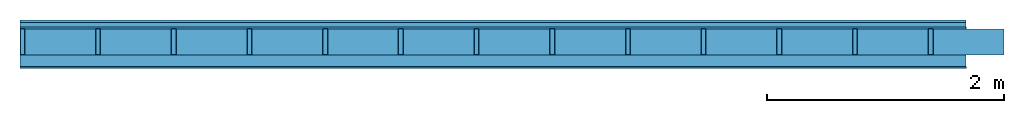
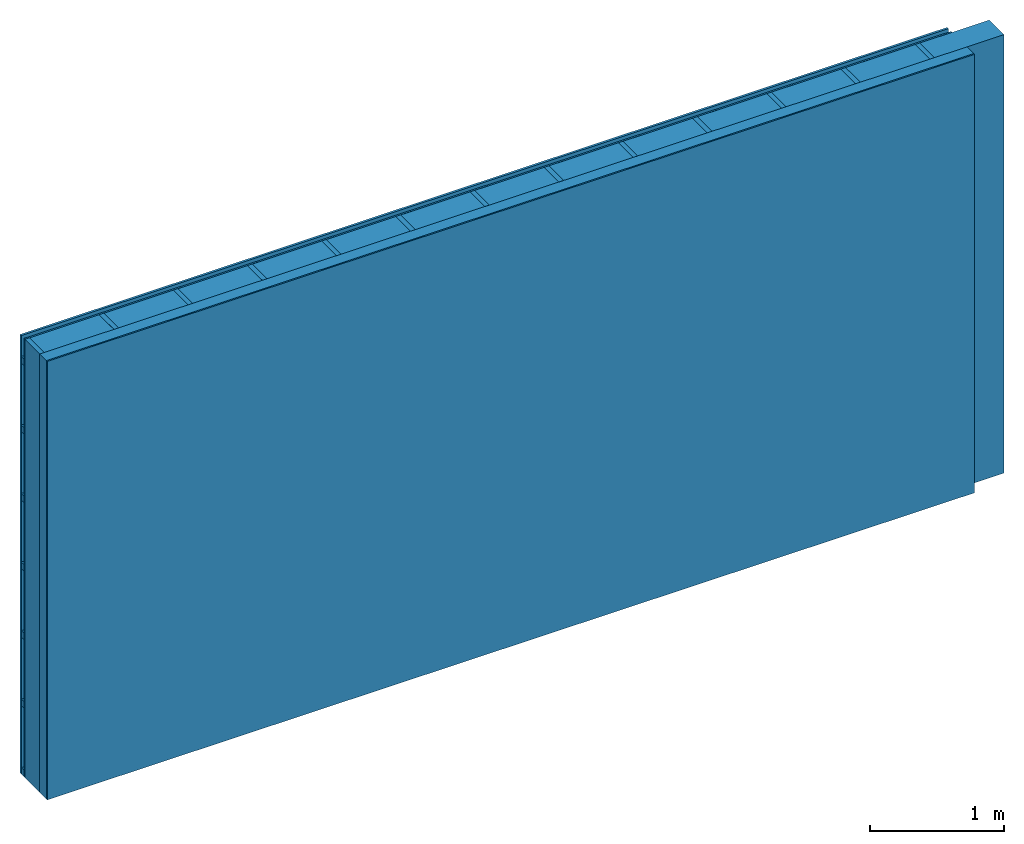
# One storey: 4 plates, 3 members, 1 element without a shape of its own.
"""IFC4 building model written with IfcOpenShell, lengths in metres."""

from ifc_helpers import new_model, si_unit, derived_unit, direction, frame, frame_2d, origin, origin_with_axes, place, context, project, spatial, rectangle, extrude, material, layer, layer_set, type_object, element, aggregate, save


model = new_model("IFC4")

# Units and contexts
plan_context = context("Plan", 3, precision=1e-05, world=origin(), true_north=direction((0.0, 1.0)))
model_context = context("Model", 3, precision=1e-05, world=origin(), true_north=direction((0.0, 1.0)))
ifc_project = project(units=[si_unit("LENGTHUNIT", "METRE"), derived_unit("SOUNDPRESSUREUNIT", [(si_unit("PRESSUREUNIT", "PASCAL", prefix="MICRO"), 0)]), si_unit("ENERGYUNIT", "JOULE", prefix="MEGA"), si_unit("MASSUNIT", "GRAM", prefix="KILO"), derived_unit("THERMALTRANSMITTANCEUNIT", [(si_unit("POWERUNIT", "WATT"), 1), (si_unit("AREAUNIT", "SQUARE_METRE"), -1), (si_unit("THERMODYNAMICTEMPERATUREUNIT", "KELVIN"), -1)]), derived_unit("AREADENSITYUNIT", [(si_unit("MASSUNIT", "GRAM", prefix="KILO"), 1), (si_unit("AREAUNIT", "SQUARE_METRE"), -1)]), derived_unit("USERDEFINED", [(si_unit("ENERGYUNIT", "JOULE", prefix="MEGA"), 1), (si_unit("AREAUNIT", "SQUARE_METRE"), -1)])], contexts=[plan_context, model_context])

# Site, building, storey
site = spatial("IfcSite", under=ifc_project)
building_placement = place(None, origin())
building = spatial("IfcBuilding", under=site, at=building_placement)
storey_placement = place(building_placement, origin())
storey = spatial("IfcBuildingStorey", under=building, at=storey_placement)

# Wall, members, plates
ifc_material_1 = material(Name="Wood cladding horizontal, closed")
ifc_layer_1 = layer(ifc_material_1, 0.02, Name="Cover 1st layer")
ifc_layer_2 = layer(None, 0.04, Name="Battens / profiles (ventilation)")
ifc_material_2 = material(Category="03.007")
ifc_layer_3 = layer(ifc_material_2, 0.015, Name="outside 1st layer")
ifc_material_3 = material(Name="of the art")
ifc_layer_4 = layer(ifc_material_3, 0.0, Name="Bond")
ifc_layer_5 = layer(None, 0.22, Name="Support")
ifc_layer_6 = layer(ifc_material_3, 0.0, Name="Bond")
ifc_material_4 = material(Name="Solid timber panel")
ifc_layer_7 = layer(ifc_material_4, 0.1, Name="1st layer")
ifc_material_5 = material(Name="Plasterboard type A", Category="03.008")
ifc_layer_8 = layer(ifc_material_5, 0.0125, Name="Covering 1st layer")
ifc_material_6 = material(Name="joints", Category="04.017")
ifc_layer_9 = layer(ifc_material_6, 0.0, Name="Surface")
ifc_layer_set = layer_set([ifc_layer_1, ifc_layer_2, ifc_layer_3, ifc_layer_4, ifc_layer_5, ifc_layer_6, ifc_layer_7, ifc_layer_8, ifc_layer_9])
wall_type = type_object("IfcWallType", Name="D0991", PredefinedType="NOTDEFINED", material=ifc_layer_set)
wall_placement = place(None, frame((0.0, 0.0, 0.0), z_axis=(0.0, -1.0, 0.0), x_axis=(1.0, 0.0, 0.0)))
wall = element("IfcWall", 1, at=wall_placement, inside=storey, type_object=wall_type, material=ifc_layer_set, Name="Wall #1")
ifc_material_7 = material()
member_1_placement = place(wall_placement, origin())
member_1 = element("IfcMember", 2, at=member_1_placement, material=ifc_material_7, Name="Battens / profiles (ventilation)", context=plan_context, shape_type="SweptSolid", body=[
    extrude(rectangle(XDim=0.06, YDim=0.04, at=frame_2d((0.03, 0.02), x_axis=(1.0, 0.0))), frame((0.0, 0.0, 0.02), z_axis=(1.0, 0.0, 0.0), x_axis=(0.0, 1.0, 0.0)), (0.0, 0.0, 1.0), 8.0),
    extrude(rectangle(XDim=0.06, YDim=0.04, at=frame_2d((0.03, 0.02), x_axis=(1.0, 0.0))), frame((0.0, 0.625, 0.02), z_axis=(1.0, 0.0, 0.0), x_axis=(0.0, 1.0, 0.0)), (0.0, 0.0, 1.0), 8.0),
    extrude(rectangle(XDim=0.06, YDim=0.04, at=frame_2d((0.03, 0.02), x_axis=(1.0, 0.0))), frame((0.0, 1.25, 0.02), z_axis=(1.0, 0.0, 0.0), x_axis=(0.0, 1.0, 0.0)), (0.0, 0.0, 1.0), 8.0),
    extrude(rectangle(XDim=0.06, YDim=0.04, at=frame_2d((0.03, 0.02), x_axis=(1.0, 0.0))), frame((0.0, 1.875, 0.02), z_axis=(1.0, 0.0, 0.0), x_axis=(0.0, 1.0, 0.0)), (0.0, 0.0, 1.0), 8.0),
    extrude(rectangle(XDim=0.06, YDim=0.04, at=frame_2d((0.03, 0.02), x_axis=(1.0, 0.0))), frame((0.0, 2.5, 0.02), z_axis=(1.0, 0.0, 0.0), x_axis=(0.0, 1.0, 0.0)), (0.0, 0.0, 1.0), 8.0),
    extrude(rectangle(XDim=0.06, YDim=0.04, at=frame_2d((0.03, 0.02), x_axis=(1.0, 0.0))), frame((0.0, 3.125, 0.02), z_axis=(1.0, 0.0, 0.0), x_axis=(0.0, 1.0, 0.0)), (0.0, 0.0, 1.0), 8.0),
    extrude(rectangle(XDim=0.06, YDim=0.04, at=frame_2d((0.03, 0.02), x_axis=(1.0, 0.0))), frame((0.0, 3.75, 0.02), z_axis=(1.0, 0.0, 0.0), x_axis=(0.0, 1.0, 0.0)), (0.0, 0.0, 1.0), 8.0),
])
ifc_material_8 = material()
member_2_placement = place(wall_placement, origin())
member_2 = element("IfcMember", 3, at=member_2_placement, material=ifc_material_8, Name="Support", context=plan_context, shape_type="SweptSolid", body=[
    extrude(rectangle(XDim=0.04, YDim=0.22, at=frame_2d((0.02, 0.11), x_axis=(1.0, 0.0))), frame((0.0, 4.0, 0.075), z_axis=(0.0, -1.0, 0.0), x_axis=(1.0, 0.0, 0.0)), (0.0, 0.0, 1.0), 4.0),
    extrude(rectangle(XDim=0.04, YDim=0.22, at=frame_2d((0.02, 0.11), x_axis=(1.0, 0.0))), frame((0.64, 4.0, 0.075), z_axis=(0.0, -1.0, 0.0), x_axis=(1.0, 0.0, 0.0)), (0.0, 0.0, 1.0), 4.0),
    extrude(rectangle(XDim=0.04, YDim=0.22, at=frame_2d((0.02, 0.11), x_axis=(1.0, 0.0))), frame((1.28, 4.0, 0.075), z_axis=(0.0, -1.0, 0.0), x_axis=(1.0, 0.0, 0.0)), (0.0, 0.0, 1.0), 4.0),
    extrude(rectangle(XDim=0.04, YDim=0.22, at=frame_2d((0.02, 0.11), x_axis=(1.0, 0.0))), frame((1.92, 4.0, 0.075), z_axis=(0.0, -1.0, 0.0), x_axis=(1.0, 0.0, 0.0)), (0.0, 0.0, 1.0), 4.0),
    extrude(rectangle(XDim=0.04, YDim=0.22, at=frame_2d((0.02, 0.11), x_axis=(1.0, 0.0))), frame((2.56, 4.0, 0.075), z_axis=(0.0, -1.0, 0.0), x_axis=(1.0, 0.0, 0.0)), (0.0, 0.0, 1.0), 4.0),
    extrude(rectangle(XDim=0.04, YDim=0.22, at=frame_2d((0.02, 0.11), x_axis=(1.0, 0.0))), frame((3.2, 4.0, 0.075), z_axis=(0.0, -1.0, 0.0), x_axis=(1.0, 0.0, 0.0)), (0.0, 0.0, 1.0), 4.0),
    extrude(rectangle(XDim=0.04, YDim=0.22, at=frame_2d((0.02, 0.11), x_axis=(1.0, 0.0))), frame((3.84, 4.0, 0.075), z_axis=(0.0, -1.0, 0.0), x_axis=(1.0, 0.0, 0.0)), (0.0, 0.0, 1.0), 4.0),
    extrude(rectangle(XDim=0.04, YDim=0.22, at=frame_2d((0.02, 0.11), x_axis=(1.0, 0.0))), frame((4.48, 4.0, 0.075), z_axis=(0.0, -1.0, 0.0), x_axis=(1.0, 0.0, 0.0)), (0.0, 0.0, 1.0), 4.0),
    extrude(rectangle(XDim=0.04, YDim=0.22, at=frame_2d((0.02, 0.11), x_axis=(1.0, 0.0))), frame((5.12, 4.0, 0.075), z_axis=(0.0, -1.0, 0.0), x_axis=(1.0, 0.0, 0.0)), (0.0, 0.0, 1.0), 4.0),
    extrude(rectangle(XDim=0.04, YDim=0.22, at=frame_2d((0.02, 0.11), x_axis=(1.0, 0.0))), frame((5.76, 4.0, 0.075), z_axis=(0.0, -1.0, 0.0), x_axis=(1.0, 0.0, 0.0)), (0.0, 0.0, 1.0), 4.0),
    extrude(rectangle(XDim=0.04, YDim=0.22, at=frame_2d((0.02, 0.11), x_axis=(1.0, 0.0))), frame((6.4, 4.0, 0.075), z_axis=(0.0, -1.0, 0.0), x_axis=(1.0, 0.0, 0.0)), (0.0, 0.0, 1.0), 4.0),
    extrude(rectangle(XDim=0.04, YDim=0.22, at=frame_2d((0.02, 0.11), x_axis=(1.0, 0.0))), frame((7.04, 4.0, 0.075), z_axis=(0.0, -1.0, 0.0), x_axis=(1.0, 0.0, 0.0)), (0.0, 0.0, 1.0), 4.0),
    extrude(rectangle(XDim=0.04, YDim=0.22, at=frame_2d((0.02, 0.11), x_axis=(1.0, 0.0))), frame((7.68, 4.0, 0.075), z_axis=(0.0, -1.0, 0.0), x_axis=(1.0, 0.0, 0.0)), (0.0, 0.0, 1.0), 4.0),
])
ifc_material_9 = material(Name="Mineral wool")
member_3_placement = place(wall_placement, origin())
member_3 = element("IfcMember", 4, at=member_3_placement, material=ifc_material_9, Name="Cavity", context=plan_context, shape_type="SweptSolid", body=[
    extrude(rectangle(XDim=0.6, YDim=0.22, at=frame_2d((0.3, 0.11), x_axis=(1.0, 0.0))), frame((0.04, 4.0, 0.075), z_axis=(0.0, -1.0, 0.0), x_axis=(1.0, 0.0, 0.0)), (0.0, 0.0, 1.0), 4.0),
    extrude(rectangle(XDim=0.6, YDim=0.22, at=frame_2d((0.3, 0.11), x_axis=(1.0, 0.0))), frame((0.68, 4.0, 0.075), z_axis=(0.0, -1.0, 0.0), x_axis=(1.0, 0.0, 0.0)), (0.0, 0.0, 1.0), 4.0),
    extrude(rectangle(XDim=0.6, YDim=0.22, at=frame_2d((0.3, 0.11), x_axis=(1.0, 0.0))), frame((1.32, 4.0, 0.075), z_axis=(0.0, -1.0, 0.0), x_axis=(1.0, 0.0, 0.0)), (0.0, 0.0, 1.0), 4.0),
    extrude(rectangle(XDim=0.6, YDim=0.22, at=frame_2d((0.3, 0.11), x_axis=(1.0, 0.0))), frame((1.96, 4.0, 0.075), z_axis=(0.0, -1.0, 0.0), x_axis=(1.0, 0.0, 0.0)), (0.0, 0.0, 1.0), 4.0),
    extrude(rectangle(XDim=0.6, YDim=0.22, at=frame_2d((0.3, 0.11), x_axis=(1.0, 0.0))), frame((2.6, 4.0, 0.075), z_axis=(0.0, -1.0, 0.0), x_axis=(1.0, 0.0, 0.0)), (0.0, 0.0, 1.0), 4.0),
    extrude(rectangle(XDim=0.6, YDim=0.22, at=frame_2d((0.3, 0.11), x_axis=(1.0, 0.0))), frame((3.24, 4.0, 0.075), z_axis=(0.0, -1.0, 0.0), x_axis=(1.0, 0.0, 0.0)), (0.0, 0.0, 1.0), 4.0),
    extrude(rectangle(XDim=0.6, YDim=0.22, at=frame_2d((0.3, 0.11), x_axis=(1.0, 0.0))), frame((3.88, 4.0, 0.075), z_axis=(0.0, -1.0, 0.0), x_axis=(1.0, 0.0, 0.0)), (0.0, 0.0, 1.0), 4.0),
    extrude(rectangle(XDim=0.6, YDim=0.22, at=frame_2d((0.3, 0.11), x_axis=(1.0, 0.0))), frame((4.52, 4.0, 0.075), z_axis=(0.0, -1.0, 0.0), x_axis=(1.0, 0.0, 0.0)), (0.0, 0.0, 1.0), 4.0),
    extrude(rectangle(XDim=0.6, YDim=0.22, at=frame_2d((0.3, 0.11), x_axis=(1.0, 0.0))), frame((5.16, 4.0, 0.075), z_axis=(0.0, -1.0, 0.0), x_axis=(1.0, 0.0, 0.0)), (0.0, 0.0, 1.0), 4.0),
    extrude(rectangle(XDim=0.6, YDim=0.22, at=frame_2d((0.3, 0.11), x_axis=(1.0, 0.0))), frame((5.8, 4.0, 0.075), z_axis=(0.0, -1.0, 0.0), x_axis=(1.0, 0.0, 0.0)), (0.0, 0.0, 1.0), 4.0),
    extrude(rectangle(XDim=0.6, YDim=0.22, at=frame_2d((0.3, 0.11), x_axis=(1.0, 0.0))), frame((6.44, 4.0, 0.075), z_axis=(0.0, -1.0, 0.0), x_axis=(1.0, 0.0, 0.0)), (0.0, 0.0, 1.0), 4.0),
    extrude(rectangle(XDim=0.6, YDim=0.22, at=frame_2d((0.3, 0.11), x_axis=(1.0, 0.0))), frame((7.08, 4.0, 0.075), z_axis=(0.0, -1.0, 0.0), x_axis=(1.0, 0.0, 0.0)), (0.0, 0.0, 1.0), 4.0),
    extrude(rectangle(XDim=0.6, YDim=0.22, at=frame_2d((0.3, 0.11), x_axis=(1.0, 0.0))), frame((7.72, 4.0, 0.075), z_axis=(0.0, -1.0, 0.0), x_axis=(1.0, 0.0, 0.0)), (0.0, 0.0, 1.0), 4.0),
])
plate_1_placement = place(wall_placement, origin())
plate_1 = element("IfcPlate", 5, at=plate_1_placement, material=ifc_material_1, Name="Cover 1st layer", context=plan_context, shape_type="SweptSolid", body=[
    extrude(rectangle(XDim=8.0, YDim=4.0, at=frame_2d((4.0, 2.0), x_axis=(1.0, 0.0))), origin_with_axes(), (0.0, 0.0, 1.0), 0.02),
])
plate_2_placement = place(wall_placement, origin())
plate_2 = element("IfcPlate", 6, at=plate_2_placement, material=ifc_material_2, Name="outside 1st layer", context=plan_context, shape_type="SweptSolid", body=[
    extrude(rectangle(XDim=8.0, YDim=4.0, at=frame_2d((4.0, 2.0), x_axis=(1.0, 0.0))), frame((0.0, 0.0, 0.06), z_axis=(0.0, 0.0, 1.0), x_axis=(1.0, 0.0, 0.0)), (0.0, 0.0, 1.0), 0.015),
])
plate_3_placement = place(wall_placement, origin())
plate_3 = element("IfcPlate", 7, at=plate_3_placement, material=ifc_material_4, Name="1st layer", context=plan_context, shape_type="SweptSolid", body=[
    extrude(rectangle(XDim=8.0, YDim=4.0, at=frame_2d((4.0, 2.0), x_axis=(1.0, 0.0))), frame((0.0, 0.0, 0.295), z_axis=(0.0, 0.0, 1.0), x_axis=(1.0, 0.0, 0.0)), (0.0, 0.0, 1.0), 0.1),
])
plate_4_placement = place(wall_placement, origin())
plate_4 = element("IfcPlate", 8, at=plate_4_placement, material=ifc_material_5, Name="Covering 1st layer", context=plan_context, shape_type="SweptSolid", body=[
    extrude(rectangle(XDim=8.0, YDim=4.0, at=frame_2d((4.0, 2.0), x_axis=(1.0, 0.0))), frame((0.0, 0.0, 0.395), z_axis=(0.0, 0.0, 1.0), x_axis=(1.0, 0.0, 0.0)), (0.0, 0.0, 1.0), 0.0125),
])
aggregate(wall, [plate_1, member_1, plate_2, member_2, member_3, plate_3, plate_4])

save(model, "model.ifc")
